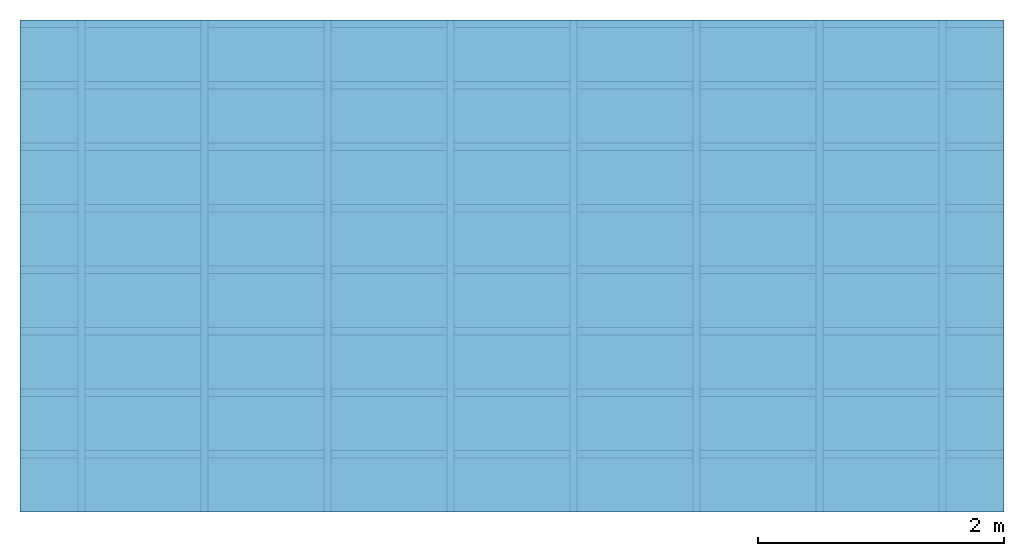
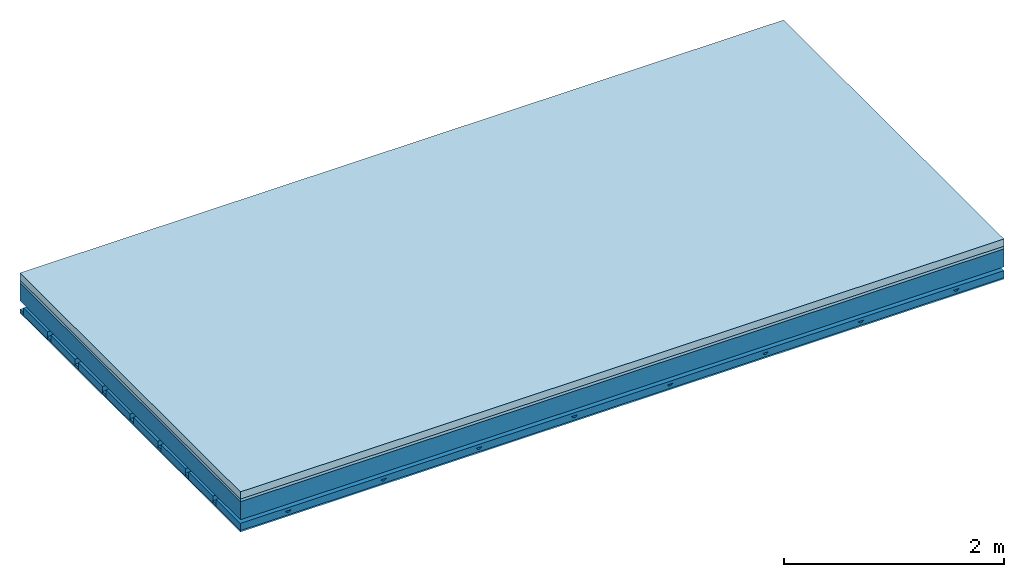
# One storey: 4 members, 3 plates, 1 element without a shape of its own.
"""IFC4 building model written with IfcOpenShell, lengths in metres."""

from ifc_helpers import new_model, si_unit, derived_unit, direction, frame, frame_2d, origin, origin_with_axes, place, context, project, spatial, polyline, rectangle, outline, extrude, material, layer, layer_set, type_object, element, aggregate, save


model = new_model("IFC4")

# Units and contexts
plan_context = context("Plan", 3, precision=1e-05, world=origin(), true_north=direction((0.0, 1.0)))
model_context = context("Model", 3, precision=1e-05, world=origin(), true_north=direction((0.0, 1.0)))
ifc_project = project(units=[si_unit("LENGTHUNIT", "METRE"), derived_unit("SOUNDPRESSUREUNIT", [(si_unit("PRESSUREUNIT", "PASCAL", prefix="MICRO"), 0)]), si_unit("ENERGYUNIT", "JOULE", prefix="MEGA"), si_unit("MASSUNIT", "GRAM", prefix="KILO"), derived_unit("THERMALTRANSMITTANCEUNIT", [(si_unit("POWERUNIT", "WATT"), 1), (si_unit("AREAUNIT", "SQUARE_METRE"), -1), (si_unit("THERMODYNAMICTEMPERATUREUNIT", "KELVIN"), -1)]), derived_unit("AREADENSITYUNIT", [(si_unit("MASSUNIT", "GRAM", prefix="KILO"), 1), (si_unit("AREAUNIT", "SQUARE_METRE"), -1)]), derived_unit("USERDEFINED", [(si_unit("ENERGYUNIT", "JOULE", prefix="MEGA"), 1), (si_unit("AREAUNIT", "SQUARE_METRE"), -1)])], contexts=[plan_context, model_context])

# Site, building, storey
site = spatial("IfcSite", under=ifc_project)
building_placement = place(None, origin())
building = spatial("IfcBuilding", under=site, at=building_placement)
storey_placement = place(building_placement, origin())
storey = spatial("IfcBuildingStorey", under=building, at=storey_placement)

# Slab, members, plates
ifc_material_1 = material(Name="Cement screed", Category="04.006")
ifc_layer_1 = layer(ifc_material_1, 0.08, Name="On-material")
ifc_material_2 = material()
ifc_layer_2 = layer(ifc_material_2, 0.03, Name="Impact sound insulation")
ifc_layer_3 = layer(None, 0.2, Name="Supporting structure")
ifc_material_3 = material(Name="no composite action")
ifc_layer_4 = layer(ifc_material_3, 0.0, Name="Bond")
ifc_layer_5 = layer(None, 0.093, Name="Coupling")
ifc_layer_6 = layer(None, 0.027, Name="Battens / profiles")
ifc_material_4 = material(Category="03.007")
ifc_layer_7 = layer(ifc_material_4, 0.015, Name="Ceiling covering 1st layer")
ifc_material_5 = material(Name="Glued joints")
ifc_layer_8 = layer(ifc_material_5, 0.0, Name="Surface / treatment")
ifc_layer_set = layer_set([ifc_layer_1, ifc_layer_2, ifc_layer_3, ifc_layer_4, ifc_layer_5, ifc_layer_6, ifc_layer_7, ifc_layer_8])
slab_type = type_object("IfcSlabType", Name="A0892", PredefinedType="NOTDEFINED", material=ifc_layer_set)
slab_placement = place(None, frame((0.0, 0.0, 0.0), z_axis=(0.0, 0.0, -1.0), x_axis=(1.0, 0.0, 0.0)))
slab = element("IfcSlab", 1, at=slab_placement, inside=storey, type_object=slab_type, material=ifc_layer_set, Name="Slab #1")
ifc_material_6 = material()
member_1_placement = place(slab_placement, origin())
member_1 = element("IfcMember", 2, at=member_1_placement, material=ifc_material_6, Name="Supporting structure", context=plan_context, shape_type="SweptSolid", body=[
    extrude(rectangle(XDim=1.0, YDim=0.2, at=frame_2d((0.5, 0.1), x_axis=(1.0, 0.0))), frame((0.0, 4.0, 0.11), z_axis=(0.0, -1.0, 0.0), x_axis=(1.0, 0.0, 0.0)), (0.0, 0.0, 1.0), 4.0),
    extrude(rectangle(XDim=1.0, YDim=0.2, at=frame_2d((0.5, 0.1), x_axis=(1.0, 0.0))), frame((1.0, 4.0, 0.11), z_axis=(0.0, -1.0, 0.0), x_axis=(1.0, 0.0, 0.0)), (0.0, 0.0, 1.0), 4.0),
    extrude(rectangle(XDim=1.0, YDim=0.2, at=frame_2d((0.5, 0.1), x_axis=(1.0, 0.0))), frame((2.0, 4.0, 0.11), z_axis=(0.0, -1.0, 0.0), x_axis=(1.0, 0.0, 0.0)), (0.0, 0.0, 1.0), 4.0),
    extrude(rectangle(XDim=1.0, YDim=0.2, at=frame_2d((0.5, 0.1), x_axis=(1.0, 0.0))), frame((3.0, 4.0, 0.11), z_axis=(0.0, -1.0, 0.0), x_axis=(1.0, 0.0, 0.0)), (0.0, 0.0, 1.0), 4.0),
    extrude(rectangle(XDim=1.0, YDim=0.2, at=frame_2d((0.5, 0.1), x_axis=(1.0, 0.0))), frame((4.0, 4.0, 0.11), z_axis=(0.0, -1.0, 0.0), x_axis=(1.0, 0.0, 0.0)), (0.0, 0.0, 1.0), 4.0),
    extrude(rectangle(XDim=1.0, YDim=0.2, at=frame_2d((0.5, 0.1), x_axis=(1.0, 0.0))), frame((5.0, 4.0, 0.11), z_axis=(0.0, -1.0, 0.0), x_axis=(1.0, 0.0, 0.0)), (0.0, 0.0, 1.0), 4.0),
    extrude(rectangle(XDim=1.0, YDim=0.2, at=frame_2d((0.5, 0.1), x_axis=(1.0, 0.0))), frame((6.0, 4.0, 0.11), z_axis=(0.0, -1.0, 0.0), x_axis=(1.0, 0.0, 0.0)), (0.0, 0.0, 1.0), 4.0),
    extrude(rectangle(XDim=1.0, YDim=0.2, at=frame_2d((0.5, 0.1), x_axis=(1.0, 0.0))), frame((7.0, 4.0, 0.11), z_axis=(0.0, -1.0, 0.0), x_axis=(1.0, 0.0, 0.0)), (0.0, 0.0, 1.0), 4.0),
])
ifc_material_7 = material()
member_2_placement = place(slab_placement, origin())
member_2 = element("IfcMember", 3, at=member_2_placement, material=ifc_material_7, Name="Coupling", context=plan_context, shape_type="SweptSolid", body=[
    extrude(outline(polyline([(0.0, 0.0), (0.06, 0.0), (0.04, 0.02), (0.02, 0.02), (0.0, 0.0)])), frame((0.47, 4.0, 0.383), z_axis=(0.0, -1.0, 0.0), x_axis=(1.0, 0.0, 0.0)), (0.0, 0.0, 1.0), 4.0),
    extrude(outline(polyline([(0.0, 0.0), (0.06, 0.0), (0.04, 0.02), (0.02, 0.02), (0.0, 0.0)])), frame((1.47, 4.0, 0.383), z_axis=(0.0, -1.0, 0.0), x_axis=(1.0, 0.0, 0.0)), (0.0, 0.0, 1.0), 4.0),
    extrude(outline(polyline([(0.0, 0.0), (0.06, 0.0), (0.04, 0.02), (0.02, 0.02), (0.0, 0.0)])), frame((2.47, 4.0, 0.383), z_axis=(0.0, -1.0, 0.0), x_axis=(1.0, 0.0, 0.0)), (0.0, 0.0, 1.0), 4.0),
    extrude(outline(polyline([(0.0, 0.0), (0.06, 0.0), (0.04, 0.02), (0.02, 0.02), (0.0, 0.0)])), frame((3.47, 4.0, 0.383), z_axis=(0.0, -1.0, 0.0), x_axis=(1.0, 0.0, 0.0)), (0.0, 0.0, 1.0), 4.0),
    extrude(outline(polyline([(0.0, 0.0), (0.06, 0.0), (0.04, 0.02), (0.02, 0.02), (0.0, 0.0)])), frame((4.47, 4.0, 0.383), z_axis=(0.0, -1.0, 0.0), x_axis=(1.0, 0.0, 0.0)), (0.0, 0.0, 1.0), 4.0),
    extrude(outline(polyline([(0.0, 0.0), (0.06, 0.0), (0.04, 0.02), (0.02, 0.02), (0.0, 0.0)])), frame((5.47, 4.0, 0.383), z_axis=(0.0, -1.0, 0.0), x_axis=(1.0, 0.0, 0.0)), (0.0, 0.0, 1.0), 4.0),
    extrude(outline(polyline([(0.0, 0.0), (0.06, 0.0), (0.04, 0.02), (0.02, 0.02), (0.0, 0.0)])), frame((6.47, 4.0, 0.383), z_axis=(0.0, -1.0, 0.0), x_axis=(1.0, 0.0, 0.0)), (0.0, 0.0, 1.0), 4.0),
    extrude(outline(polyline([(0.0, 0.0), (0.06, 0.0), (0.04, 0.02), (0.02, 0.02), (0.0, 0.0)])), frame((7.47, 4.0, 0.383), z_axis=(0.0, -1.0, 0.0), x_axis=(1.0, 0.0, 0.0)), (0.0, 0.0, 1.0), 4.0),
])
ifc_material_8 = material()
member_3_placement = place(slab_placement, origin())
member_3 = element("IfcMember", 4, at=member_3_placement, material=ifc_material_8, Name="Battens / profiles", context=plan_context, shape_type="SweptSolid", body=[
    extrude(rectangle(XDim=0.06, YDim=0.027, at=frame_2d((0.03, 0.0135), x_axis=(1.0, 0.0))), frame((0.0, 0.0, 0.403), z_axis=(1.0, 0.0, 0.0), x_axis=(0.0, 1.0, 0.0)), (0.0, 0.0, 1.0), 8.0),
    extrude(rectangle(XDim=0.06, YDim=0.027, at=frame_2d((0.03, 0.0135), x_axis=(1.0, 0.0))), frame((0.0, 0.5, 0.403), z_axis=(1.0, 0.0, 0.0), x_axis=(0.0, 1.0, 0.0)), (0.0, 0.0, 1.0), 8.0),
    extrude(rectangle(XDim=0.06, YDim=0.027, at=frame_2d((0.03, 0.0135), x_axis=(1.0, 0.0))), frame((0.0, 1.0, 0.403), z_axis=(1.0, 0.0, 0.0), x_axis=(0.0, 1.0, 0.0)), (0.0, 0.0, 1.0), 8.0),
    extrude(rectangle(XDim=0.06, YDim=0.027, at=frame_2d((0.03, 0.0135), x_axis=(1.0, 0.0))), frame((0.0, 1.5, 0.403), z_axis=(1.0, 0.0, 0.0), x_axis=(0.0, 1.0, 0.0)), (0.0, 0.0, 1.0), 8.0),
    extrude(rectangle(XDim=0.06, YDim=0.027, at=frame_2d((0.03, 0.0135), x_axis=(1.0, 0.0))), frame((0.0, 2.0, 0.403), z_axis=(1.0, 0.0, 0.0), x_axis=(0.0, 1.0, 0.0)), (0.0, 0.0, 1.0), 8.0),
    extrude(rectangle(XDim=0.06, YDim=0.027, at=frame_2d((0.03, 0.0135), x_axis=(1.0, 0.0))), frame((0.0, 2.5, 0.403), z_axis=(1.0, 0.0, 0.0), x_axis=(0.0, 1.0, 0.0)), (0.0, 0.0, 1.0), 8.0),
    extrude(rectangle(XDim=0.06, YDim=0.027, at=frame_2d((0.03, 0.0135), x_axis=(1.0, 0.0))), frame((0.0, 3.0, 0.403), z_axis=(1.0, 0.0, 0.0), x_axis=(0.0, 1.0, 0.0)), (0.0, 0.0, 1.0), 8.0),
    extrude(rectangle(XDim=0.06, YDim=0.027, at=frame_2d((0.03, 0.0135), x_axis=(1.0, 0.0))), frame((0.0, 3.5, 0.403), z_axis=(1.0, 0.0, 0.0), x_axis=(0.0, 1.0, 0.0)), (0.0, 0.0, 1.0), 8.0),
])
ifc_material_9 = material()
member_4_placement = place(slab_placement, origin())
member_4 = element("IfcMember", 5, at=member_4_placement, material=ifc_material_9, Name="Cavity", context=plan_context, shape_type="SweptSolid", body=[
    extrude(rectangle(XDim=0.44, YDim=0.08, at=frame_2d((0.22, 0.04), x_axis=(1.0, 0.0))), frame((0.0, 0.06, 0.35), z_axis=(1.0, 0.0, 0.0), x_axis=(0.0, 1.0, 0.0)), (0.0, 0.0, 1.0), 8.0),
    extrude(rectangle(XDim=0.44, YDim=0.08, at=frame_2d((0.22, 0.04), x_axis=(1.0, 0.0))), frame((0.0, 0.56, 0.35), z_axis=(1.0, 0.0, 0.0), x_axis=(0.0, 1.0, 0.0)), (0.0, 0.0, 1.0), 8.0),
    extrude(rectangle(XDim=0.44, YDim=0.08, at=frame_2d((0.22, 0.04), x_axis=(1.0, 0.0))), frame((0.0, 1.06, 0.35), z_axis=(1.0, 0.0, 0.0), x_axis=(0.0, 1.0, 0.0)), (0.0, 0.0, 1.0), 8.0),
    extrude(rectangle(XDim=0.44, YDim=0.08, at=frame_2d((0.22, 0.04), x_axis=(1.0, 0.0))), frame((0.0, 1.56, 0.35), z_axis=(1.0, 0.0, 0.0), x_axis=(0.0, 1.0, 0.0)), (0.0, 0.0, 1.0), 8.0),
    extrude(rectangle(XDim=0.44, YDim=0.08, at=frame_2d((0.22, 0.04), x_axis=(1.0, 0.0))), frame((0.0, 2.06, 0.35), z_axis=(1.0, 0.0, 0.0), x_axis=(0.0, 1.0, 0.0)), (0.0, 0.0, 1.0), 8.0),
    extrude(rectangle(XDim=0.44, YDim=0.08, at=frame_2d((0.22, 0.04), x_axis=(1.0, 0.0))), frame((0.0, 2.56, 0.35), z_axis=(1.0, 0.0, 0.0), x_axis=(0.0, 1.0, 0.0)), (0.0, 0.0, 1.0), 8.0),
    extrude(rectangle(XDim=0.44, YDim=0.08, at=frame_2d((0.22, 0.04), x_axis=(1.0, 0.0))), frame((0.0, 3.06, 0.35), z_axis=(1.0, 0.0, 0.0), x_axis=(0.0, 1.0, 0.0)), (0.0, 0.0, 1.0), 8.0),
    extrude(rectangle(XDim=0.44, YDim=0.08, at=frame_2d((0.22, 0.04), x_axis=(1.0, 0.0))), frame((0.0, 3.56, 0.35), z_axis=(1.0, 0.0, 0.0), x_axis=(0.0, 1.0, 0.0)), (0.0, 0.0, 1.0), 8.0),
])
plate_1_placement = place(slab_placement, origin())
plate_1 = element("IfcPlate", 6, at=plate_1_placement, material=ifc_material_1, Name="On-material", context=plan_context, shape_type="SweptSolid", body=[
    extrude(rectangle(XDim=8.0, YDim=4.0, at=frame_2d((4.0, 2.0), x_axis=(1.0, 0.0))), origin_with_axes(), (0.0, 0.0, 1.0), 0.08),
])
plate_2_placement = place(slab_placement, origin())
plate_2 = element("IfcPlate", 7, at=plate_2_placement, material=ifc_material_2, Name="Impact sound insulation", context=plan_context, shape_type="SweptSolid", body=[
    extrude(rectangle(XDim=8.0, YDim=4.0, at=frame_2d((4.0, 2.0), x_axis=(1.0, 0.0))), frame((0.0, 0.0, 0.08), z_axis=(0.0, 0.0, 1.0), x_axis=(1.0, 0.0, 0.0)), (0.0, 0.0, 1.0), 0.03),
])
plate_3_placement = place(slab_placement, origin())
plate_3 = element("IfcPlate", 8, at=plate_3_placement, material=ifc_material_4, Name="Ceiling covering 1st layer", context=plan_context, shape_type="SweptSolid", body=[
    extrude(rectangle(XDim=8.0, YDim=4.0, at=frame_2d((4.0, 2.0), x_axis=(1.0, 0.0))), frame((0.0, 0.0, 0.43), z_axis=(0.0, 0.0, 1.0), x_axis=(1.0, 0.0, 0.0)), (0.0, 0.0, 1.0), 0.015),
])
aggregate(slab, [plate_1, plate_2, member_1, member_2, member_3, member_4, plate_3])

save(model, "model.ifc")
